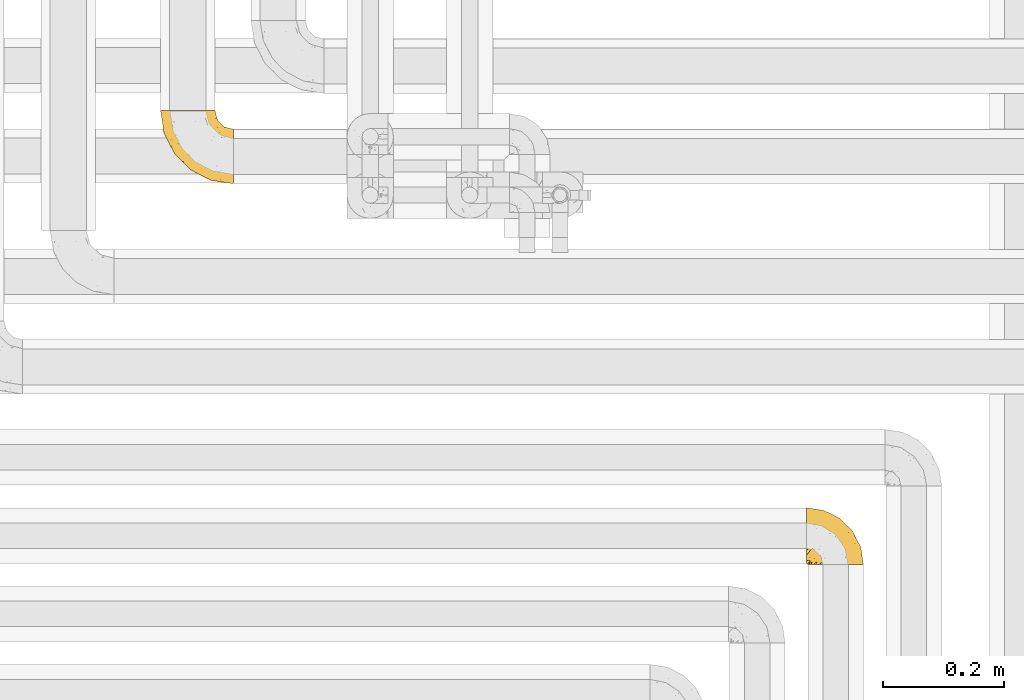
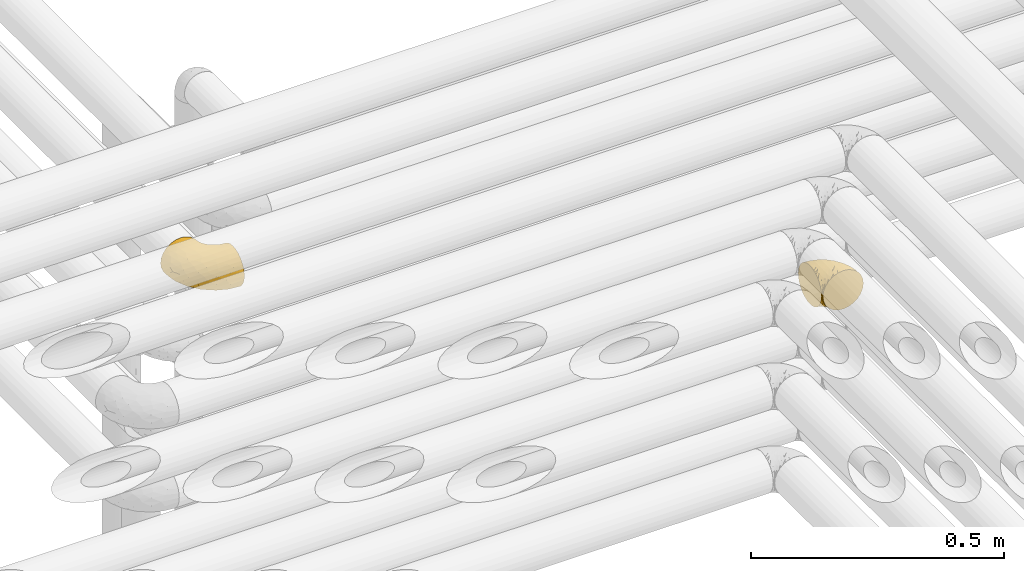
# One storey, part 275 of 827: 2 coverings.
"""IFC2X3 building model written with IfcOpenShell, lengths in millimetres."""

from ifc_helpers import new_model, entity, si_unit, converted_unit, derived_unit, direction, frame, origin, place, context, subcontext, project, spatial, faceted_brep, element, save


model = new_model("IFC2X3")

# Units and contexts
model_context = context("Model", 3, precision=0.01, world=origin(), true_north=direction((6.12303176911189e-17, 1.0)))
body_context = subcontext(model_context, "Body", "Model", "MODEL_VIEW")
ifc_project = project(units=[si_unit("LENGTHUNIT", "METRE", prefix="MILLI"), si_unit("AREAUNIT", "SQUARE_METRE"), si_unit("VOLUMEUNIT", "CUBIC_METRE"), converted_unit("PLANEANGLEUNIT", "DEGREE", entity("IfcRatioMeasure", 0.0174532925199433), si_unit("PLANEANGLEUNIT", "RADIAN"), dimensions=[0, 0, 0, 0, 0, 0, 0]), si_unit("MASSUNIT", "GRAM", prefix="KILO"), derived_unit("MASSDENSITYUNIT", [(si_unit("MASSUNIT", "GRAM", prefix="KILO"), 1), (si_unit("LENGTHUNIT", "METRE"), -3)]), derived_unit("MOMENTOFINERTIAUNIT", [(si_unit("LENGTHUNIT", "METRE"), 4)]), si_unit("TIMEUNIT", "SECOND"), si_unit("FREQUENCYUNIT", "HERTZ"), si_unit("THERMODYNAMICTEMPERATUREUNIT", "DEGREE_CELSIUS"), derived_unit("THERMALTRANSMITTANCEUNIT", [(si_unit("MASSUNIT", "GRAM", prefix="KILO"), 1), (si_unit("THERMODYNAMICTEMPERATUREUNIT", "KELVIN"), -1), (si_unit("TIMEUNIT", "SECOND"), -3)]), derived_unit("VOLUMETRICFLOWRATEUNIT", [(si_unit("LENGTHUNIT", "METRE"), 3), (si_unit("TIMEUNIT", "SECOND"), -1)]), derived_unit("MASSFLOWRATEUNIT", [(si_unit("MASSUNIT", "GRAM", prefix="KILO"), 1), (si_unit("TIMEUNIT", "SECOND"), -1)]), derived_unit("ROTATIONALFREQUENCYUNIT", [(si_unit("TIMEUNIT", "SECOND"), -1)]), si_unit("ELECTRICCURRENTUNIT", "AMPERE"), si_unit("ELECTRICVOLTAGEUNIT", "VOLT"), si_unit("POWERUNIT", "WATT"), si_unit("FORCEUNIT", "NEWTON", prefix="KILO"), si_unit("ILLUMINANCEUNIT", "LUX"), si_unit("LUMINOUSFLUXUNIT", "LUMEN"), si_unit("LUMINOUSINTENSITYUNIT", "CANDELA"), derived_unit("USERDEFINED", [(si_unit("MASSUNIT", "GRAM", prefix="KILO"), -1), (si_unit("LENGTHUNIT", "METRE"), -2), (si_unit("TIMEUNIT", "SECOND"), 3), (si_unit("LUMINOUSFLUXUNIT", "LUMEN"), 1)]), derived_unit("LINEARVELOCITYUNIT", [(si_unit("LENGTHUNIT", "METRE"), 1), (si_unit("TIMEUNIT", "SECOND"), -1)]), si_unit("PRESSUREUNIT", "PASCAL"), derived_unit("USERDEFINED", [(si_unit("LENGTHUNIT", "METRE"), -2), (si_unit("MASSUNIT", "GRAM", prefix="KILO"), 1), (si_unit("TIMEUNIT", "SECOND"), -2)]), derived_unit("LINEARFORCEUNIT", [(si_unit("MASSUNIT", "GRAM", prefix="KILO"), 1), (si_unit("LENGTHUNIT", "METRE"), 1), (si_unit("TIMEUNIT", "SECOND"), -2), (si_unit("LENGTHUNIT", "METRE"), -1)]), derived_unit("PLANARFORCEUNIT", [(si_unit("MASSUNIT", "GRAM", prefix="KILO"), 1), (si_unit("LENGTHUNIT", "METRE"), 1), (si_unit("TIMEUNIT", "SECOND"), -2), (si_unit("LENGTHUNIT", "METRE"), -2)])], contexts=[model_context])

# Site, building, storey
site_placement = place(None, origin())
site = spatial("IfcSite", under=ifc_project, at=site_placement, CompositionType="ELEMENT")
building_placement = place(site_placement, origin())
building = spatial("IfcBuilding", under=site, at=building_placement, CompositionType="ELEMENT")
storey_placement = place(building_placement, frame((0.0, 0.0, 28200.0)))
storey = spatial("IfcBuildingStorey", under=building, at=storey_placement, Name="08", CompositionType="ELEMENT", Elevation=28200.0)

# Coverings
covering_1_placement = place(storey_placement, frame((35550.5, 14310.41, 3152.2)))
element("IfcCovering", 1, at=covering_1_placement, inside=storey, Name=":ADSK_", ObjectType=":ADSK_", PredefinedType="INSULATION", context=body_context, shape_type="Brep", body=[
    faceted_brep([(1.6, 78.41, 83.91), (1.6, 85.72, 76.59), (1.6, 91.22, 67.83), (1.6, 94.64, 58.07), (1.6, 95.8, 47.8), (1.6, 94.64, 37.51), (1.6, 91.22, 27.74), (1.6, 85.71, 18.98), (1.6, 78.39, 11.67), (1.6, 69.63, 6.17), (1.6, 59.87, 2.75), (1.6, 49.6, 1.6), (1.6, 45.45, 2.06), (1.6, 42.38, 2.41), (1.6, 39.31, 2.75), (1.6, 34.43, 4.46), (1.6, 29.54, 6.17), (1.6, 25.16, 8.93), (1.6, 20.78, 11.68), (1.6, 17.13, 15.34), (1.6, 13.47, 19.0), (1.6, 7.97, 27.76), (1.6, 6.26, 32.64), (1.6, 4.55, 37.52), (1.6, 3.4, 47.8), (1.6, 4.55, 58.08), (1.6, 6.26, 62.96), (1.6, 7.97, 67.85), (1.6, 13.48, 76.61), (1.6, 17.14, 80.26), (1.6, 20.8, 83.92), (1.6, 25.18, 86.67), (1.6, 29.56, 89.42), (1.6, 34.44, 91.13), (1.6, 39.32, 92.84), (1.6, 42.39, 93.18), (1.6, 45.45, 93.53), (1.6, 49.6, 94.0), (1.6, 59.88, 92.84), (1.6, 69.65, 89.42), (3.4, 1.6, 47.8), (4.97, 1.6, 35.84), (9.58, 1.6, 24.7), (13.26, 1.6, 19.91), (16.93, 1.6, 15.13), (21.71, 1.6, 11.46), (26.5, 1.6, 7.78), (32.07, 1.6, 5.48), (37.64, 1.6, 3.17), (41.25, 1.6, 2.69), (43.34, 1.6, 2.42), (45.42, 1.6, 2.14), (49.6, 1.6, 1.6), (61.55, 1.6, 3.17), (72.7, 1.6, 7.78), (82.26, 1.6, 15.13), (89.61, 1.6, 24.7), (94.22, 1.6, 35.84), (95.8, 1.6, 47.8), (94.22, 1.6, 59.75), (89.61, 1.6, 70.9), (82.26, 1.6, 80.46), (72.7, 1.6, 87.81), (61.55, 1.6, 92.42), (49.6, 1.6, 94.0), (45.42, 1.6, 93.45), (41.25, 1.6, 92.9), (37.64, 1.6, 92.42), (32.07, 1.6, 90.11), (26.5, 1.6, 87.81), (21.71, 1.6, 84.13), (16.93, 1.6, 80.46), (13.26, 1.6, 75.68), (9.58, 1.6, 70.9), (4.97, 1.6, 59.75), (81.55, 36.81, 71.98), (90.4, 23.28, 63.6), (83.0, 45.8, 59.72), (91.18, 30.7, 47.8), (93.13, 21.2, 55.16), (94.0, 12.96, 47.8), (66.19, 66.19, 63.76), (70.92, 54.51, 72.22), (85.95, 17.98, 74.18), (49.74, 36.69, 92.52), (35.54, 35.54, 94.0), (38.14, 31.64, 94.0), (40.74, 27.75, 94.0), (43.34, 23.86, 94.0), (45.94, 19.96, 94.0), (77.59, 22.8, 82.14), (71.17, 42.67, 80.34), (65.81, 33.21, 87.52), (59.03, 59.45, 79.59), (45.85, 71.5, 78.25), (45.79, 62.66, 85.01), (41.42, 54.5, 90.25), (34.51, 47.57, 93.2), (56.04, 48.81, 87.23), (15.15, 74.98, 85.55), (56.51, 18.7, 93.0), (68.39, 15.75, 89.31), (23.33, 91.17, 61.31), (42.86, 85.28, 56.86), (39.42, 82.58, 68.34), (53.58, 75.78, 65.71), (59.17, 74.98, 56.99), (59.06, 67.27, 72.15), (22.63, 87.38, 70.34), (20.55, 82.04, 78.36), (12.96, 94.0, 47.8), (56.96, 77.8, 47.8), (67.38, 67.38, 47.8), (18.72, 56.2, 93.06), (5.33, 48.85, 94.0), (9.07, 48.11, 94.0), (11.79, 47.57, 94.0), (14.51, 47.03, 94.0), (17.24, 46.48, 94.0), (19.96, 45.94, 94.0), (21.03, 65.78, 89.88), (46.48, 17.24, 94.0), (47.03, 14.51, 94.0), (47.57, 11.79, 94.0), (48.11, 9.07, 94.0), (48.48, 7.2, 94.0), (48.85, 5.33, 94.0), (30.7, 91.18, 47.8), (23.86, 43.34, 94.0), (27.75, 40.74, 94.0), (31.64, 38.14, 94.0), (31.26, 72.73, 83.7), (77.8, 56.96, 47.8), (72.75, 62.23, 55.9), (43.83, 84.49, 47.8), (84.49, 43.83, 47.8), (14.58, 12.05, 81.75), (16.17, 18.95, 86.43), (10.82, 13.02, 79.8), (4.64, 8.34, 69.84), (7.71, 14.63, 79.5), (25.13, 11.09, 88.08), (32.66, 13.66, 91.6), (34.94, 20.08, 92.93), (36.76, 9.61, 92.43), (40.48, 9.48, 93.24), (39.25, 16.1, 93.36), (3.69, 3.42, 57.25), (13.99, 26.63, 89.41), (21.85, 33.72, 92.89), (17.93, 34.77, 92.66), (15.11, 6.75, 79.58), (21.14, 13.31, 86.51), (7.21, 19.94, 83.91), (9.47, 27.05, 88.76), (32.27, 8.67, 90.94), (25.68, 26.11, 91.94), (22.18, 29.3, 91.98), (18.79, 6.32, 82.79), (10.12, 39.92, 93.16), (10.45, 6.04, 73.94), (11.29, 34.4, 91.89), (2.87, 2.87, 47.8), (31.16, 20.92, 92.22), (12.7, 21.11, 86.29), (6.31, 27.43, 88.56), (25.62, 7.54, 87.72), (21.18, 18.45, 88.33), (28.81, 23.88, 92.18), (7.45, 7.77, 71.78), (21.14, 13.3, 9.09), (25.13, 11.09, 7.51), (18.79, 6.33, 12.8), (48.85, 5.33, 1.6), (47.03, 14.51, 1.6), (47.57, 11.79, 1.6), (48.11, 9.07, 1.6), (3.69, 3.42, 38.35), (7.44, 7.76, 23.84), (14.51, 47.03, 1.6), (11.79, 47.57, 1.6), (5.33, 48.85, 1.6), (9.07, 48.11, 1.6), (7.71, 14.62, 16.1), (9.47, 27.03, 6.84), (34.94, 20.08, 2.66), (31.16, 20.92, 3.37), (40.74, 27.75, 1.6), (38.14, 31.64, 1.6), (36.76, 9.61, 3.16), (40.48, 9.48, 2.35), (4.63, 8.33, 25.77), (15.11, 6.74, 16.02), (14.58, 12.04, 13.85), (43.34, 23.86, 1.6), (45.94, 19.96, 1.6), (39.25, 16.1, 2.23), (7.21, 19.93, 11.69), (12.69, 21.1, 9.31), (10.14, 39.92, 2.43), (21.81, 33.68, 2.71), (22.19, 29.28, 3.61), (14.0, 26.62, 6.18), (25.69, 26.08, 3.66), (16.17, 18.93, 9.17), (6.66, 27.87, 6.77), (17.92, 34.75, 2.93), (10.45, 6.04, 21.66), (31.64, 38.14, 1.6), (10.64, 12.79, 16.09), (11.31, 34.41, 3.7), (19.96, 45.94, 1.6), (23.86, 43.34, 1.6), (27.75, 40.74, 1.6), (32.66, 13.66, 3.99), (46.48, 17.24, 1.6), (32.27, 8.67, 4.65), (35.54, 35.54, 1.6), (28.77, 23.83, 3.43), (21.17, 18.43, 7.27), (23.36, 6.03, 9.46), (17.24, 46.48, 1.6), (47.58, 34.52, 2.4), (93.13, 21.2, 40.43), (77.44, 23.82, 13.57), (66.78, 41.32, 11.3), (71.68, 47.62, 18.65), (74.96, 52.66, 27.26), (81.55, 36.81, 23.61), (36.7, 49.75, 3.07), (56.9, 19.07, 2.69), (83.0, 45.8, 35.87), (90.4, 23.28, 31.99), (67.83, 21.35, 6.71), (85.95, 17.98, 21.41), (39.41, 82.57, 27.24), (23.33, 91.17, 34.26), (42.87, 85.27, 38.73), (53.92, 73.89, 26.97), (66.19, 66.19, 31.83), (64.12, 62.43, 23.4), (33.13, 63.53, 6.91), (23.1, 58.45, 3.4), (16.98, 67.16, 5.84), (55.72, 76.72, 35.73), (72.75, 62.22, 39.69), (23.77, 81.54, 17.6), (18.41, 74.8, 10.38), (43.7, 75.83, 20.6), (54.53, 41.45, 5.36), (17.73, 88.2, 24.84), (38.98, 71.6, 13.87), (50.28, 56.23, 9.06), (59.02, 59.44, 15.99)], [[[0, 1, 2, 3, 4, 5, 6, 7, 8, 9, 10, 11, 12, 13, 14, 15, 16, 17, 18, 19, 20, 21, 22, 23, 24, 25, 26, 27, 28, 29, 30, 31, 32, 33, 34, 35, 36, 37, 38, 39]], [[40, 41, 42, 43, 44, 45, 46, 47, 48, 49, 50, 51, 52, 53, 54, 55, 56, 57, 58, 59, 60, 61, 62, 63, 64, 65, 66, 67, 68, 69, 70, 71, 72, 73, 74]], [[75, 76, 77]], [[78, 79, 80]], [[77, 81, 82]], [[76, 75, 83]], [[84, 85, 86, 87, 88, 89]], [[90, 91, 92]], [[76, 60, 59]], [[93, 94, 95]], [[90, 62, 61]], [[83, 61, 60]], [[96, 97, 84]], [[98, 93, 95]], [[0, 39, 99]], [[100, 84, 89]], [[62, 101, 63]], [[2, 102, 3]], [[92, 84, 100]], [[103, 102, 104]], [[103, 105, 106]], [[93, 107, 94]], [[1, 108, 2]], [[92, 101, 90]], [[108, 1, 109]], [[102, 110, 3]], [[93, 82, 107]], [[102, 108, 104]], [[111, 106, 112]], [[109, 0, 99]], [[113, 37, 114, 115, 116, 117, 118, 119]], [[120, 38, 113]], [[100, 89, 121, 122, 123, 124, 125, 126, 64]], [[127, 102, 103]], [[97, 119, 128, 129, 130, 85]], [[99, 120, 131]], [[132, 133, 77]], [[59, 80, 79]], [[1, 0, 109]], [[98, 84, 92]], [[94, 109, 131]], [[120, 39, 38]], [[93, 91, 82]], [[104, 94, 105]], [[97, 113, 119]], [[95, 120, 96]], [[83, 90, 61]], [[91, 93, 98]], [[64, 63, 100]], [[100, 63, 101]], [[77, 76, 79]], [[133, 106, 81]], [[84, 97, 85]], [[113, 96, 120]], [[113, 97, 96]], [[37, 113, 38]], [[110, 102, 127]], [[110, 4, 3]], [[103, 111, 134, 127]], [[90, 75, 91]], [[82, 81, 107]], [[91, 75, 82]], [[77, 82, 75]], [[76, 83, 60]], [[90, 83, 75]], [[105, 107, 81]], [[94, 131, 95]], [[105, 94, 107]], [[109, 94, 104]], [[120, 95, 131]], [[98, 95, 96]], [[84, 98, 96]], [[98, 92, 91]], [[106, 105, 81]], [[103, 104, 105]], [[112, 106, 133]], [[103, 106, 111]], [[112, 133, 132]], [[81, 77, 133]], [[77, 78, 135, 132]], [[120, 99, 39]], [[109, 99, 131]], [[59, 58, 80]], [[59, 79, 76]], [[90, 101, 62]], [[100, 101, 92]], [[2, 108, 102]], [[109, 104, 108]], [[78, 77, 79]], [[136, 137, 138]], [[27, 139, 140]], [[141, 142, 143]], [[144, 145, 121]], [[146, 89, 88]], [[147, 139, 25]], [[148, 149, 150]], [[136, 151, 152]], [[147, 40, 74]], [[24, 147, 25]], [[153, 148, 154]], [[33, 116, 34]], [[73, 72, 151]], [[114, 37, 36, 35, 34, 116, 115]], [[146, 155, 144]], [[156, 85, 130]], [[157, 149, 148]], [[151, 158, 152]], [[117, 33, 159]], [[29, 153, 154]], [[160, 74, 73]], [[161, 128, 119]], [[66, 65, 64, 126, 125, 124, 123, 122, 67]], [[162, 147, 24]], [[27, 140, 28]], [[149, 129, 150]], [[139, 27, 26, 25]], [[68, 144, 69]], [[129, 128, 150]], [[163, 87, 86]], [[130, 129, 149]], [[122, 145, 67]], [[153, 164, 148]], [[161, 119, 159]], [[165, 30, 154]], [[150, 154, 148]], [[128, 161, 150]], [[30, 165, 31]], [[145, 144, 68]], [[89, 146, 144]], [[87, 163, 143]], [[166, 155, 142]], [[88, 87, 143]], [[161, 154, 150]], [[154, 30, 29]], [[29, 28, 153]], [[28, 140, 153]], [[164, 153, 140]], [[140, 137, 164]], [[157, 148, 164]], [[156, 130, 157]], [[164, 137, 157]], [[157, 137, 156]], [[167, 137, 136]], [[168, 85, 156]], [[152, 168, 167]], [[167, 168, 156]], [[163, 152, 141]], [[71, 158, 72]], [[152, 167, 136]], [[88, 142, 146]], [[144, 155, 69]], [[146, 142, 155]], [[70, 166, 71]], [[142, 141, 166]], [[70, 69, 155]], [[141, 158, 71]], [[160, 73, 151]], [[138, 137, 140]], [[160, 136, 169]], [[136, 160, 151]], [[74, 160, 169]], [[152, 158, 141]], [[151, 72, 158]], [[168, 152, 163]], [[137, 167, 156]], [[163, 86, 168]], [[85, 168, 86]], [[116, 33, 117]], [[130, 149, 157]], [[67, 145, 68]], [[121, 89, 144]], [[145, 122, 121]], [[40, 147, 162]], [[169, 147, 74]], [[159, 33, 32]], [[161, 159, 32]], [[159, 119, 118, 117]], [[139, 147, 169]], [[139, 169, 138]], [[161, 32, 31]], [[141, 143, 163]], [[88, 143, 142]], [[71, 166, 141]], [[155, 166, 70]], [[139, 138, 140]], [[169, 136, 138]], [[154, 161, 165]], [[161, 31, 165]], [[170, 171, 172]], [[173, 52, 51, 50, 49, 48, 174, 175, 176]], [[177, 178, 41]], [[179, 15, 180]], [[12, 11, 181, 182, 180, 14, 13]], [[183, 21, 20]], [[19, 18, 184]], [[185, 186, 187]], [[186, 188, 187]], [[43, 172, 44]], [[189, 190, 47]], [[23, 22, 21, 191]], [[170, 192, 193]], [[40, 162, 177]], [[194, 195, 196]], [[24, 23, 177]], [[197, 198, 183]], [[199, 15, 179]], [[47, 46, 189]], [[200, 201, 202]], [[201, 203, 204]], [[205, 206, 184]], [[207, 41, 178]], [[16, 15, 199]], [[14, 180, 15]], [[202, 201, 198]], [[208, 201, 200]], [[162, 24, 177]], [[48, 47, 190]], [[196, 195, 189]], [[197, 184, 202]], [[204, 193, 209]], [[210, 211, 212]], [[206, 212, 213]], [[205, 17, 210]], [[184, 206, 202]], [[210, 212, 206]], [[185, 194, 214]], [[189, 215, 190]], [[216, 45, 214]], [[186, 171, 170]], [[189, 216, 196]], [[197, 20, 19]], [[194, 185, 187]], [[197, 183, 20]], [[184, 197, 19]], [[197, 202, 198]], [[206, 200, 202]], [[204, 183, 198]], [[201, 208, 203]], [[203, 208, 217]], [[204, 198, 201]], [[217, 188, 218]], [[193, 219, 170]], [[171, 186, 185]], [[170, 218, 186]], [[170, 219, 218]], [[42, 207, 192]], [[171, 220, 172]], [[216, 189, 46]], [[214, 194, 196]], [[44, 220, 45]], [[214, 196, 216]], [[216, 46, 45]], [[214, 45, 220]], [[192, 43, 42]], [[204, 203, 219]], [[207, 193, 192]], [[209, 193, 178]], [[41, 207, 42]], [[193, 207, 178]], [[43, 192, 172]], [[170, 172, 192]], [[204, 219, 193]], [[219, 203, 218]], [[217, 218, 203]], [[188, 186, 218]], [[206, 213, 200]], [[208, 200, 213]], [[199, 210, 16]], [[215, 189, 195]], [[215, 174, 190]], [[174, 48, 190]], [[199, 179, 221, 211]], [[210, 199, 211]], [[23, 191, 177]], [[40, 177, 41]], [[183, 209, 191]], [[183, 191, 21]], [[191, 178, 177]], [[205, 18, 17]], [[17, 16, 210]], [[171, 185, 214]], [[172, 220, 44]], [[214, 220, 171]], [[191, 209, 178]], [[204, 209, 183]], [[206, 205, 210]], [[18, 205, 184]], [[222, 195, 194, 187, 188, 217]], [[57, 223, 80]], [[224, 225, 226]], [[226, 227, 228]], [[229, 217, 208, 213, 212, 211]], [[230, 52, 173, 176, 175, 174, 215, 195]], [[231, 232, 228]], [[231, 78, 223]], [[223, 57, 232]], [[224, 233, 225]], [[233, 54, 53]], [[234, 232, 56]], [[56, 55, 234]], [[234, 224, 228]], [[235, 236, 237]], [[224, 55, 54]], [[238, 239, 240]], [[52, 230, 53]], [[241, 242, 243]], [[239, 244, 245]], [[11, 10, 242]], [[236, 6, 5]], [[7, 246, 8]], [[8, 247, 9]], [[238, 248, 235]], [[222, 229, 249]], [[242, 211, 221, 179, 180, 182, 181, 11]], [[233, 53, 230]], [[111, 112, 244]], [[250, 6, 236]], [[247, 251, 241]], [[6, 250, 7]], [[127, 236, 110]], [[249, 229, 252]], [[247, 8, 246]], [[235, 246, 250]], [[236, 5, 110]], [[235, 244, 238]], [[237, 236, 127]], [[243, 9, 247]], [[252, 229, 241]], [[56, 232, 57]], [[222, 230, 195]], [[225, 249, 252]], [[249, 233, 230]], [[54, 233, 224]], [[231, 228, 227]], [[245, 132, 231]], [[249, 225, 233]], [[226, 225, 253]], [[235, 250, 236]], [[246, 7, 250]], [[251, 247, 246]], [[243, 247, 241]], [[248, 246, 235]], [[252, 251, 253]], [[229, 222, 217]], [[230, 222, 249]], [[5, 4, 110]], [[237, 127, 134, 111]], [[238, 244, 239]], [[224, 234, 55]], [[232, 234, 228]], [[242, 241, 229]], [[10, 9, 243]], [[211, 242, 229]], [[10, 243, 242]], [[80, 223, 78]], [[80, 58, 57]], [[231, 223, 232]], [[227, 240, 239]], [[224, 226, 228]], [[240, 226, 253]], [[227, 239, 245]], [[226, 240, 227]], [[251, 248, 253]], [[240, 253, 248]], [[244, 235, 237]], [[237, 111, 244]], [[132, 245, 112]], [[112, 245, 244]], [[135, 78, 231, 132]], [[227, 245, 231]], [[248, 238, 240]], [[246, 248, 251]], [[251, 252, 241]], [[225, 252, 253]]]),
])
covering_2_placement = place(storey_placement, frame((34478.29, 14942.26, 3153.25)))
element("IfcCovering", 2, at=covering_2_placement, inside=storey, Name=":ADSK_", ObjectType=":ADSK_", PredefinedType="INSULATION", context=body_context, shape_type="Brep", body=[
    faceted_brep([(122.75, 36.69, 90.76), (122.75, 27.15, 87.42), (122.75, 18.59, 82.04), (122.75, 11.44, 74.89), (122.75, 6.06, 66.33), (122.75, 2.73, 56.79), (122.75, 1.6, 46.75), (122.75, 2.73, 36.69), (122.75, 6.07, 27.15), (122.75, 11.45, 18.59), (122.75, 18.6, 11.44), (122.75, 27.16, 6.06), (122.75, 36.7, 2.73), (122.75, 46.75, 1.6), (122.75, 56.8, 2.73), (122.75, 66.34, 6.07), (122.75, 74.9, 11.45), (122.75, 82.05, 18.6), (122.75, 87.43, 27.16), (122.75, 90.76, 36.7), (122.75, 91.9, 46.75), (122.75, 90.76, 56.8), (122.75, 87.42, 66.34), (122.75, 82.04, 74.9), (122.75, 74.89, 82.05), (122.75, 66.33, 87.43), (122.75, 56.79, 90.76), (122.75, 46.75, 91.9), (90.36, 122.75, 35.06), (85.85, 122.75, 24.17), (78.67, 122.75, 14.82), (69.32, 122.75, 7.64), (58.43, 122.75, 3.13), (46.75, 122.75, 1.6), (35.06, 122.75, 3.13), (24.17, 122.75, 7.64), (14.82, 122.75, 14.82), (7.64, 122.75, 24.17), (3.13, 122.75, 35.06), (1.6, 122.75, 46.75), (3.13, 122.75, 58.43), (7.64, 122.75, 69.32), (14.82, 122.75, 78.67), (24.17, 122.75, 85.85), (35.06, 122.75, 90.36), (46.75, 122.75, 91.9), (58.43, 122.75, 90.36), (69.32, 122.75, 85.85), (78.67, 122.75, 78.67), (85.85, 122.75, 69.32), (90.36, 122.75, 58.43), (91.9, 122.75, 46.75), (51.54, 24.73, 46.75), (47.17, 29.08, 55.2), (38.13, 38.13, 46.75), (7.52, 85.31, 46.75), (5.85, 93.59, 54.53), (5.11, 100.54, 46.75), (19.2, 63.54, 59.63), (38.98, 38.98, 62.07), (35.02, 50.71, 71.86), (8.21, 93.33, 62.65), (19.28, 75.2, 71.33), (12.19, 100.46, 72.93), (101.39, 41.6, 91.2), (34.43, 80.86, 86.31), (20.95, 94.87, 80.89), (30.74, 67.96, 79.49), (72.93, 52.16, 90.68), (56.64, 52.1, 86.84), (80.81, 36.74, 87.38), (93.43, 17.11, 76.87), (100.76, 23.24, 83.73), (74.27, 29.18, 81.03), (93.66, 52.53, 91.9), (81.33, 60.77, 91.9), (69.01, 69.01, 91.9), (40.87, 100.68, 91.03), (29.38, 103.79, 87.58), (67.05, 16.37, 56.52), (85.31, 7.52, 46.75), (93.68, 7.31, 60.4), (52.53, 93.66, 91.9), (50.71, 102.83, 91.9), (48.88, 112.01, 91.9), (72.77, 18.17, 67.87), (51.21, 71.97, 90.35), (101.18, 9.83, 69.57), (100.54, 5.11, 46.75), (48.74, 45.97, 79.91), (112.01, 48.88, 91.9), (102.83, 50.71, 91.9), (73.88, 22.83, 74.99), (24.73, 51.54, 46.75), (60.77, 81.33, 91.9), (103.08, 31.74, 88.53), (54.8, 32.48, 72.65), (16.13, 68.42, 46.75), (55.92, 25.33, 62.97), (68.42, 16.13, 46.75), (104.98, 92.29, 66.2), (108.58, 94.12, 56.6), (98.21, 100.97, 59.89), (61.56, 95.91, 90.95), (60.69, 107.9, 90.22), (100.0, 87.24, 76.64), (95.88, 95.46, 71.58), (90.81, 90.41, 79.99), (84.88, 74.17, 89.54), (73.29, 83.77, 89.97), (113.4, 76.72, 81.32), (109.8, 84.44, 74.56), (102.13, 76.42, 84.15), (67.29, 90.07, 90.37), (70.34, 99.69, 87.82), (95.15, 61.74, 90.98), (105.49, 58.16, 90.96), (71.5, 112.6, 85.14), (92.87, 110.45, 58.11), (96.03, 107.32, 46.75), (81.34, 108.48, 78.39), (107.44, 66.63, 88.22), (88.36, 115.23, 66.06), (90.43, 105.79, 68.6), (114.37, 89.6, 63.78), (98.41, 69.39, 88.42), (88.73, 66.99, 90.61), (76.89, 102.31, 83.8), (86.08, 99.54, 77.98), (112.64, 55.27, 91.22), (94.21, 82.03, 83.46), (112.22, 94.71, 46.75), (107.32, 96.03, 46.75), (79.95, 94.11, 84.66), (84.51, 84.21, 86.33), (101.67, 101.67, 46.75), (94.71, 112.22, 46.75), (81.34, 108.48, 15.1), (76.89, 102.31, 9.69), (86.08, 99.54, 15.52), (79.96, 94.11, 8.83), (92.87, 110.46, 35.39), (113.41, 76.74, 12.18), (102.83, 50.71, 1.6), (105.5, 58.17, 2.53), (112.64, 55.27, 2.27), (108.58, 94.12, 36.9), (104.98, 92.3, 27.31), (98.2, 100.98, 33.62), (98.4, 69.41, 5.07), (102.13, 76.44, 9.36), (107.44, 66.65, 5.27), (88.36, 115.24, 27.43), (50.71, 102.83, 1.6), (48.88, 112.01, 1.6), (94.22, 82.05, 10.05), (100.01, 87.25, 16.87), (71.5, 112.6, 8.35), (60.69, 107.9, 3.27), (52.53, 93.66, 1.6), (95.89, 95.48, 21.94), (114.37, 89.6, 29.72), (81.33, 60.77, 1.6), (69.01, 69.01, 1.6), (84.88, 74.17, 3.96), (112.01, 48.88, 1.6), (109.8, 84.45, 18.95), (61.56, 95.91, 2.54), (67.29, 90.07, 3.12), (60.77, 81.33, 1.6), (95.14, 61.75, 2.51), (73.29, 83.77, 3.52), (84.53, 84.21, 7.17), (93.66, 52.53, 1.6), (90.82, 90.42, 13.52), (88.73, 67.0, 2.88), (70.34, 99.69, 5.67), (90.43, 105.8, 24.89), (20.95, 94.87, 12.6), (34.43, 80.86, 7.18), (30.74, 67.95, 14.0), (19.29, 75.17, 22.16), (35.07, 50.65, 21.61), (51.21, 71.97, 3.14), (56.67, 52.08, 6.65), (54.85, 32.46, 20.82), (38.98, 38.98, 31.41), (29.38, 103.79, 5.91), (40.87, 100.68, 2.46), (19.2, 63.54, 33.87), (8.21, 93.32, 30.84), (5.85, 93.59, 38.96), (12.19, 100.44, 20.56), (72.93, 52.17, 2.81), (80.83, 36.75, 6.1), (101.39, 41.61, 2.29), (93.69, 7.31, 33.08), (93.43, 17.12, 16.61), (67.04, 16.37, 36.96), (100.76, 23.26, 9.75), (72.78, 18.17, 25.61), (55.93, 25.33, 30.5), (101.18, 9.84, 23.91), (74.27, 29.19, 12.45), (73.89, 22.84, 18.49), (103.09, 31.75, 4.96), (48.78, 45.96, 13.56), (47.19, 29.07, 38.28)], [[[0, 1, 2, 3, 4, 5, 6, 7, 8, 9, 10, 11, 12, 13, 14, 15, 16, 17, 18, 19, 20, 21, 22, 23, 24, 25, 26, 27]], [[28, 29, 30, 31, 32, 33, 34, 35, 36, 37, 38, 39, 40, 41, 42, 43, 44, 45, 46, 47, 48, 49, 50, 51]], [[52, 53, 54]], [[55, 56, 57]], [[58, 59, 60]], [[61, 62, 63]], [[27, 64, 0]], [[65, 66, 67]], [[41, 40, 61]], [[68, 69, 70]], [[66, 43, 42]], [[63, 42, 41]], [[71, 72, 73]], [[72, 2, 1]], [[68, 74, 75, 76]], [[45, 44, 77]], [[43, 78, 44]], [[79, 80, 81]], [[77, 82, 83, 84, 45]], [[79, 81, 85]], [[71, 2, 72]], [[65, 86, 77]], [[4, 81, 5]], [[66, 65, 78]], [[4, 3, 87]], [[81, 88, 5]], [[63, 66, 42]], [[68, 70, 64]], [[67, 60, 89]], [[71, 3, 2]], [[64, 27, 90, 91, 74]], [[92, 71, 73]], [[40, 57, 56]], [[59, 93, 54]], [[86, 76, 94, 82]], [[1, 0, 95]], [[58, 62, 61]], [[60, 96, 89]], [[85, 81, 87]], [[56, 97, 58]], [[65, 67, 69]], [[87, 81, 4]], [[67, 89, 69]], [[61, 63, 41]], [[95, 72, 1]], [[73, 72, 70]], [[69, 73, 70]], [[73, 89, 96]], [[3, 71, 87]], [[85, 87, 71]], [[58, 61, 56]], [[59, 58, 93]], [[76, 86, 68]], [[69, 89, 73]], [[68, 86, 69]], [[65, 69, 86]], [[68, 64, 74]], [[95, 64, 70]], [[98, 79, 85]], [[79, 52, 99, 80]], [[66, 62, 67]], [[62, 58, 60]], [[62, 60, 67]], [[59, 98, 96]], [[59, 96, 60]], [[96, 85, 92]], [[88, 81, 80]], [[88, 6, 5]], [[66, 63, 62]], [[64, 95, 0]], [[72, 95, 70]], [[77, 44, 78]], [[86, 82, 77]], [[40, 39, 57]], [[96, 98, 85]], [[40, 56, 61]], [[66, 78, 43]], [[77, 78, 65]], [[79, 98, 53]], [[96, 92, 73]], [[85, 71, 92]], [[97, 56, 55]], [[97, 93, 58]], [[53, 98, 59]], [[54, 53, 59]], [[79, 53, 52]], [[100, 101, 102]], [[46, 45, 84, 83]], [[103, 104, 82]], [[82, 104, 83]], [[105, 106, 107]], [[108, 109, 76]], [[110, 111, 112]], [[103, 113, 114]], [[115, 74, 116]], [[48, 47, 117]], [[118, 102, 119]], [[49, 48, 120]], [[74, 91, 116]], [[116, 121, 115]], [[49, 122, 50]], [[123, 106, 102]], [[124, 111, 22]], [[125, 126, 115]], [[23, 22, 111]], [[24, 110, 121]], [[120, 127, 128]], [[90, 26, 129]], [[27, 26, 90]], [[121, 125, 115]], [[24, 121, 25]], [[130, 105, 107]], [[129, 25, 116]], [[21, 20, 131]], [[120, 123, 122]], [[112, 105, 130]], [[50, 118, 51]], [[21, 124, 22]], [[101, 131, 132]], [[117, 120, 48]], [[24, 23, 110]], [[127, 114, 133]], [[75, 108, 76]], [[107, 134, 130]], [[133, 114, 113]], [[129, 116, 91]], [[25, 121, 116]], [[121, 112, 125]], [[75, 74, 115]], [[101, 135, 102]], [[131, 101, 21]], [[101, 100, 124]], [[128, 127, 133]], [[119, 136, 51, 118]], [[104, 47, 46]], [[83, 104, 46]], [[117, 104, 114]], [[101, 124, 21]], [[111, 124, 100]], [[102, 118, 123]], [[133, 134, 107]], [[111, 110, 23]], [[114, 104, 103]], [[94, 76, 109]], [[121, 110, 112]], [[122, 118, 50]], [[134, 109, 108]], [[133, 107, 128]], [[112, 108, 125]], [[126, 125, 108]], [[108, 75, 126]], [[75, 115, 126]], [[109, 134, 133]], [[130, 108, 112]], [[108, 130, 134]], [[105, 112, 111]], [[111, 100, 105]], [[106, 105, 100]], [[102, 106, 100]], [[128, 106, 123]], [[90, 129, 91]], [[25, 129, 26]], [[104, 117, 47]], [[117, 114, 127]], [[82, 94, 103]], [[113, 94, 109]], [[94, 113, 103]], [[133, 113, 109]], [[106, 128, 107]], [[123, 120, 128]], [[120, 122, 49]], [[118, 122, 123]], [[135, 101, 132]], [[135, 119, 102]], [[117, 127, 120]], [[30, 29, 137]], [[138, 139, 140]], [[51, 136, 119, 141]], [[142, 17, 16]], [[143, 144, 145]], [[146, 147, 148]], [[149, 150, 151]], [[152, 29, 28]], [[33, 32, 153, 154]], [[150, 155, 156]], [[157, 31, 30]], [[153, 158, 159]], [[29, 152, 137]], [[148, 141, 119]], [[156, 160, 147]], [[148, 135, 146]], [[137, 138, 157]], [[19, 161, 146]], [[162, 163, 164]], [[14, 13, 165]], [[153, 32, 158]], [[147, 161, 166]], [[18, 17, 166]], [[167, 168, 169]], [[166, 150, 156]], [[151, 150, 142]], [[151, 170, 149]], [[151, 16, 15]], [[171, 140, 172]], [[165, 143, 145]], [[173, 170, 144]], [[142, 166, 17]], [[19, 131, 20]], [[144, 170, 151]], [[18, 161, 19]], [[173, 144, 143]], [[140, 139, 174]], [[171, 164, 163]], [[164, 172, 155]], [[151, 15, 144]], [[145, 15, 14]], [[173, 162, 170]], [[149, 175, 164]], [[19, 146, 131]], [[132, 131, 146]], [[160, 148, 147]], [[159, 158, 167]], [[135, 132, 146]], [[158, 32, 31]], [[157, 158, 31]], [[167, 158, 176]], [[166, 161, 18]], [[146, 161, 147]], [[148, 177, 141]], [[171, 168, 140]], [[171, 163, 169]], [[151, 142, 16]], [[166, 142, 150]], [[152, 141, 177]], [[51, 141, 28]], [[138, 140, 176]], [[172, 140, 174]], [[175, 149, 170]], [[164, 150, 149]], [[170, 162, 175]], [[162, 164, 175]], [[155, 172, 174]], [[171, 172, 164]], [[155, 174, 156]], [[164, 155, 150]], [[160, 156, 174]], [[147, 166, 156]], [[139, 160, 174]], [[148, 160, 177]], [[15, 145, 144]], [[165, 145, 14]], [[137, 157, 30]], [[158, 157, 176]], [[168, 167, 176]], [[169, 159, 167]], [[140, 168, 176]], [[169, 168, 171]], [[137, 177, 139]], [[160, 139, 177]], [[141, 152, 28]], [[137, 152, 177]], [[148, 119, 135]], [[157, 138, 176]], [[139, 138, 137]], [[178, 179, 180]], [[181, 180, 182]], [[179, 183, 184]], [[185, 186, 182]], [[187, 188, 179]], [[188, 33, 154, 153, 159]], [[181, 189, 190]], [[35, 34, 187]], [[191, 38, 190]], [[192, 178, 181]], [[179, 184, 180]], [[192, 190, 37]], [[37, 190, 38]], [[36, 35, 178]], [[54, 93, 186]], [[35, 187, 178]], [[193, 194, 184]], [[195, 173, 143, 165, 13]], [[195, 193, 173]], [[193, 163, 162, 173]], [[13, 12, 195]], [[8, 7, 196]], [[9, 197, 10]], [[198, 80, 99, 52]], [[196, 7, 88]], [[197, 199, 10]], [[182, 189, 181]], [[200, 198, 201]], [[200, 196, 198]], [[9, 8, 202]], [[194, 199, 203]], [[192, 37, 36]], [[80, 196, 88]], [[183, 159, 169, 163]], [[188, 34, 33]], [[202, 200, 197]], [[185, 203, 204]], [[202, 8, 196]], [[10, 199, 11]], [[12, 11, 205]], [[38, 191, 57]], [[189, 97, 191]], [[203, 199, 197]], [[205, 199, 194]], [[204, 203, 197]], [[184, 203, 206]], [[200, 202, 196]], [[197, 9, 202]], [[207, 54, 186]], [[97, 55, 191]], [[194, 203, 184]], [[183, 163, 193]], [[184, 206, 180]], [[183, 193, 184]], [[205, 195, 12]], [[193, 195, 194]], [[80, 198, 196]], [[207, 186, 201]], [[182, 180, 206]], [[181, 178, 180]], [[185, 182, 206]], [[182, 186, 189]], [[203, 185, 206]], [[185, 200, 201]], [[7, 6, 88]], [[178, 192, 36]], [[190, 192, 181]], [[199, 205, 11]], [[195, 205, 194]], [[159, 183, 188]], [[179, 188, 183]], [[57, 191, 55]], [[57, 39, 38]], [[189, 191, 190]], [[188, 187, 34]], [[178, 187, 179]], [[186, 93, 189]], [[197, 200, 204]], [[185, 204, 200]], [[189, 93, 97]], [[207, 198, 52]], [[185, 201, 186]], [[198, 207, 201]], [[54, 207, 52]]]),
])

save(model, "model.ifc")
